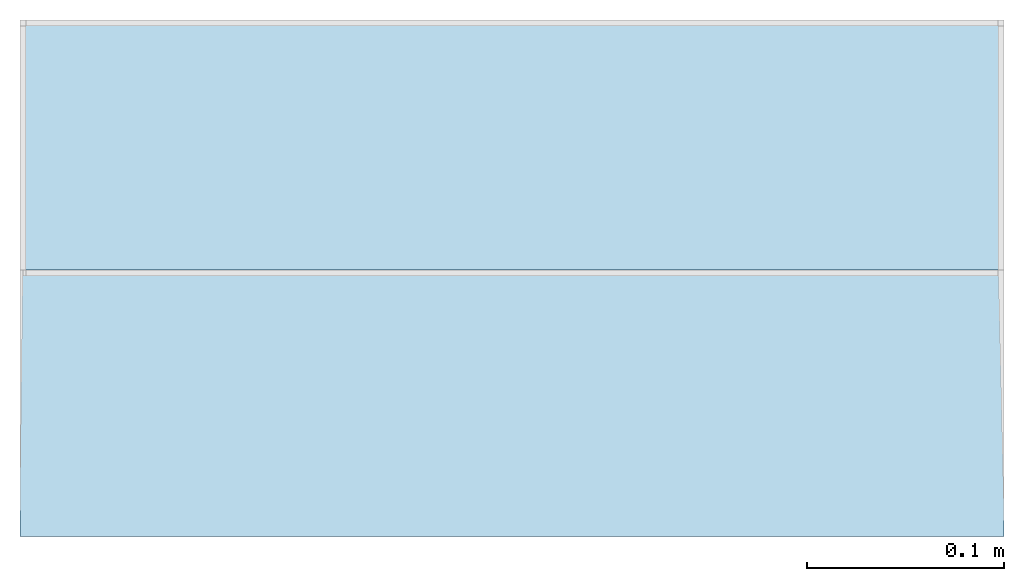
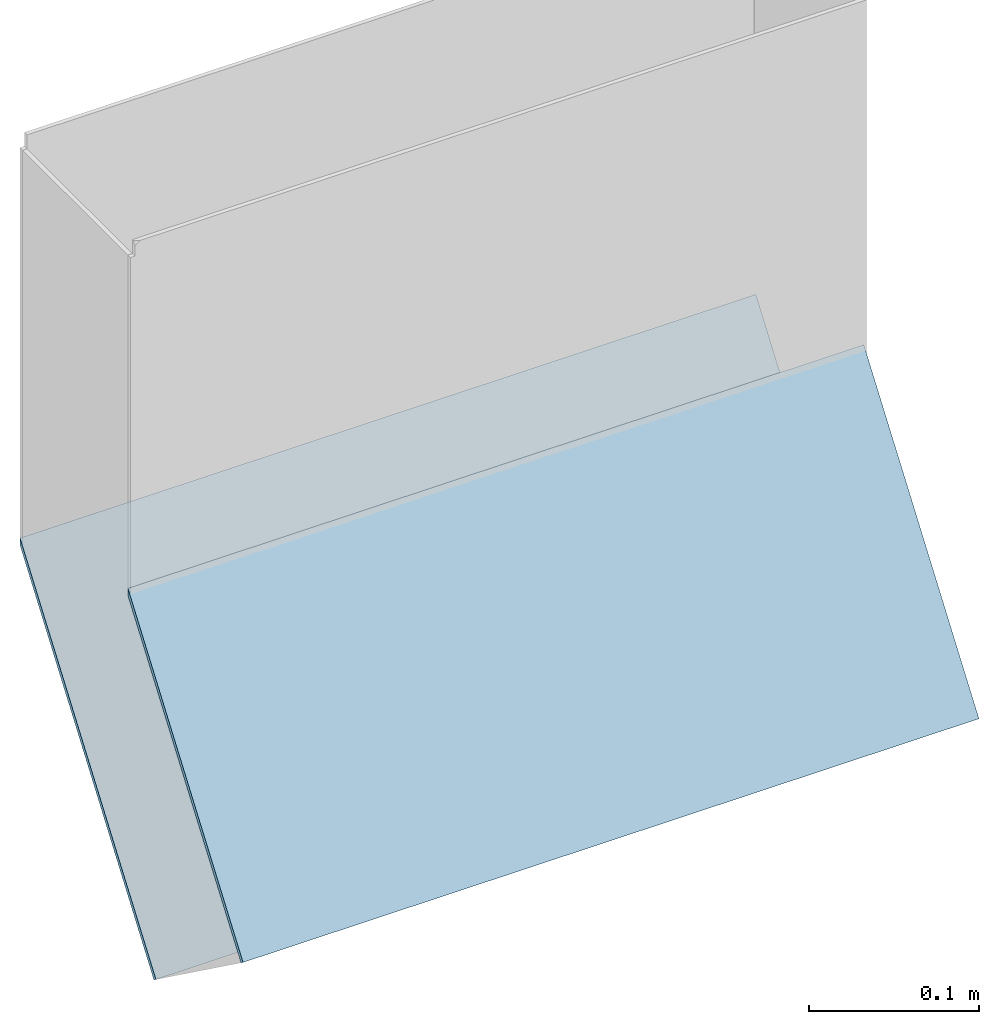
# One storey, part 1 of 2: 2 roofs.
"""IFC2X3 building model written with IfcOpenShell, lengths in metres."""

from ifc_helpers import new_model, entity, si_unit, converted_unit, derived_unit, money_unit, direction, frame, origin_with_axes, place, context, subcontext, project, spatial, faceted_brep, material, element, save


model = new_model("IFC2X3")

# Units and contexts
model_context = context("Model", 3, precision=1e-05, world=origin_with_axes(), true_north=direction((0.0, 1.0)))
plan_context = context("Plan", 3, precision=1e-05, world=origin_with_axes(), true_north=direction((0.0, 1.0)))
body_context = subcontext(model_context, "Body", "Model", "MODEL_VIEW")
ifc_project = project(units=[si_unit("LENGTHUNIT", "METRE"), si_unit("AREAUNIT", "SQUARE_METRE"), si_unit("VOLUMEUNIT", "CUBIC_METRE"), converted_unit("PLANEANGLEUNIT", "DEGREE", entity("IfcPlaneAngleMeasure", 0.0174532925199), si_unit("PLANEANGLEUNIT", "RADIAN"), dimensions=[0, 0, 0, 0, 0, 0, 0]), si_unit("SOLIDANGLEUNIT", "STERADIAN"), money_unit("CHF"), converted_unit("TIMEUNIT", "Year", entity("IfcTimeMeasure", 31556926.0), si_unit("TIMEUNIT", "SECOND"), dimensions=[0, 0, 1, 0, 0, 0, 0]), si_unit("MASSUNIT", "GRAM", prefix="KILO"), si_unit("THERMODYNAMICTEMPERATUREUNIT", "DEGREE_CELSIUS"), si_unit("LUMINOUSINTENSITYUNIT", "LUMEN"), si_unit("ENERGYUNIT", "JOULE", prefix="MEGA"), derived_unit("THERMALCONDUCTANCEUNIT", [(si_unit("POWERUNIT", "WATT"), 1), (si_unit("LENGTHUNIT", "METRE"), -1), (si_unit("THERMODYNAMICTEMPERATUREUNIT", "KELVIN"), -1)]), derived_unit("SPECIFICHEATCAPACITYUNIT", [(si_unit("ENERGYUNIT", "JOULE"), 1), (si_unit("MASSUNIT", "GRAM", prefix="KILO"), -1), (si_unit("THERMODYNAMICTEMPERATUREUNIT", "KELVIN"), -1)]), derived_unit("MASSDENSITYUNIT", [(si_unit("MASSUNIT", "GRAM", prefix="KILO"), 1), (si_unit("VOLUMEUNIT", "CUBIC_METRE"), -1)])], contexts=[model_context, plan_context])

# Site, building, storey
site_placement = place(None, origin_with_axes())
site = spatial("IfcSite", under=ifc_project, at=site_placement, CompositionType="ELEMENT")
building_placement = place(site_placement, origin_with_axes())
building = spatial("IfcBuilding", under=site, at=building_placement, CompositionType="ELEMENT")
storey_placement = place(building_placement, frame((0.0, 0.0, -2.96), z_axis=(0.0, 0.0, 1.0), x_axis=(1.0, 0.0, 0.0)))
storey = spatial("IfcBuildingStorey", under=building, at=storey_placement, Name="UG01", CompositionType="ELEMENT", Elevation=-2.96)

# Roofs
ifc_material = material(Name="Allgemein, Aussen")
roof_1_placement = place(storey_placement, frame((1.76729741952e-10, 9.19330287884, 2.96), z_axis=(0.0, 0.0, 1.0), x_axis=(1.0, 0.0, 0.0)))
element("IfcRoof", 1, at=roof_1_placement, inside=storey, material=ifc_material, Name="Dach-003", ShapeType="NOTDEFINED", context=body_context, shape_type="Brep", body=[
    faceted_brep([(9.1152243682, -8.09743070609, -0.28027621526), (9.1152243682, -8.25737500117, -0.500420651298), (9.61522436814, -8.25737500117, -0.500420651298), (9.61522436814, -8.09743070609, -0.28027621526), (9.115224368, -8.25496715349, -0.502242632474), (9.115224368, -8.09743070583, -0.285412314535), (9.61522436857, -8.25496715349, -0.502242632474), (9.61522436857, -8.09743070583, -0.285412314535)], [[[0, 1, 2, 3]], [[4, 1, 0, 5]], [[1, 4, 2]], [[2, 6, 7, 3]], [[5, 0, 3, 7]], [[4, 5, 7, 6]], [[2, 4, 6]]]),
])
roof_2_placement = place(storey_placement, frame((1.76729741952e-10, 9.19330287884, 2.96), z_axis=(0.0, 0.0, 1.0), x_axis=(1.0, 0.0, 0.0)))
element("IfcRoof", 2, at=roof_2_placement, inside=storey, material=ifc_material, Name="Dach-003", ShapeType="NOTDEFINED", context=body_context, shape_type="Brep", body=[
    faceted_brep([(9.1152243682, -8.3599272765, -0.425984639359), (9.61522436814, -8.3599272765, -0.425984639359), (9.61522436814, -8.22443070609, -0.23948960955), (9.1152243682, -8.22443070609, -0.23948960955), (9.115224368, -8.357484916, -0.427759118136), (9.61522436857, -8.357484916, -0.427759118136), (9.61522436857, -8.22443070583, -0.244625708824), (9.115224368, -8.22443070583, -0.244625708824)], [[[0, 1, 2, 3]], [[0, 4, 1]], [[1, 5, 6, 2]], [[7, 3, 2, 6]], [[4, 0, 3, 7]], [[1, 4, 5]], [[4, 7, 6, 5]]]),
])

save(model, "model.ifc")
